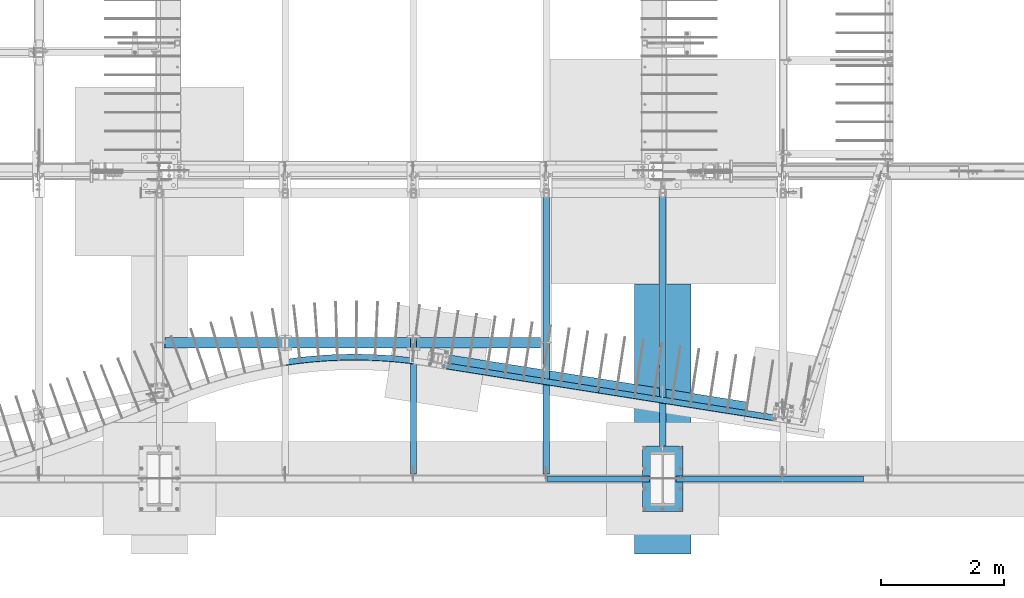
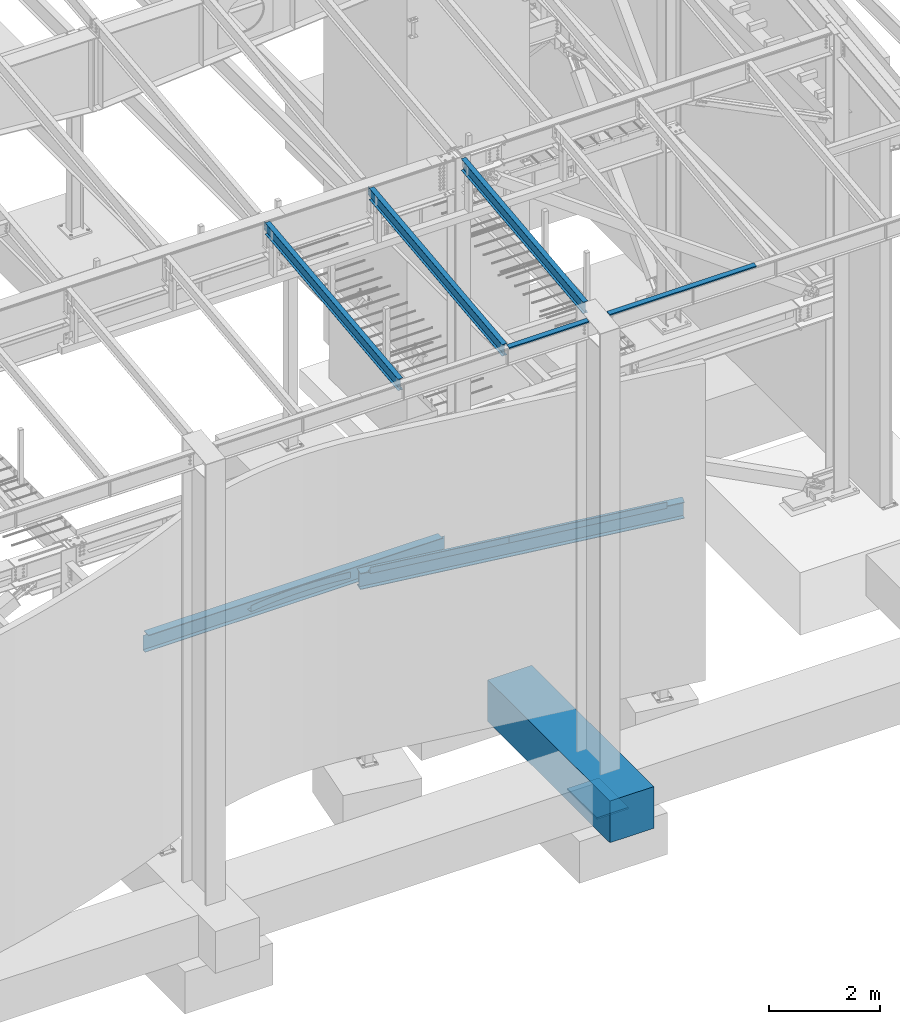
# One storey, part 712 of 1179: 12 beams, 10 elements without a shape of their own.
"""IFC2X3 building model written with IfcOpenShell, lengths in millimetres."""

from ifc_helpers import new_model, si_unit, frame, origin_with_axes, place, context, subcontext, project, spatial, faceted_brep, material, type_object, element, aggregate, save


model = new_model("IFC2X3")

# Units and contexts
model_context = context("Model", 3, precision=1e-05, world=origin_with_axes())
body_context = subcontext(model_context, "Body", "Model", "MODEL_VIEW")
ifc_project = project(units=[si_unit("LENGTHUNIT", "METRE", prefix="MILLI"), si_unit("AREAUNIT", "SQUARE_METRE"), si_unit("VOLUMEUNIT", "CUBIC_METRE"), si_unit("MASSUNIT", "GRAM", prefix="KILO"), si_unit("TIMEUNIT", "SECOND"), si_unit("PLANEANGLEUNIT", "RADIAN"), si_unit("SOLIDANGLEUNIT", "STERADIAN"), si_unit("THERMODYNAMICTEMPERATUREUNIT", "DEGREE_CELSIUS"), si_unit("LUMINOUSINTENSITYUNIT", "LUMEN")], contexts=[model_context])

# Site, building, storey
site_placement = place(None, origin_with_axes())
site = spatial("IfcSite", under=ifc_project, at=site_placement, CompositionType="ELEMENT")
building_placement = place(site_placement, origin_with_axes())
building = spatial("IfcBuilding", under=site, at=building_placement, Name="Undefined", CompositionType="ELEMENT")
storey_placement = place(building_placement, origin_with_axes())
storey = spatial("IfcBuildingStorey", under=building, at=storey_placement, Name="Undefined", CompositionType="ELEMENT", Elevation=0.0)

# Assembly, beam
assembly_1_placement = place(storey_placement, origin_with_axes())
assembly_1 = element("IfcElementAssembly", 1, at=assembly_1_placement, inside=storey, Name="BEAM", AssemblyPlace="NOTDEFINED", PredefinedType="RIGID_FRAME")
ifc_material_1 = material(Name="STEEL/A992")
beam_type_1 = type_object("IfcBeamType", Name="W10X12", PredefinedType="NOTDEFINED")
beam_1_placement = place(assembly_1_placement, frame((16459.2, 452.231593993459, 9171.78056384809), z_axis=(-3.89779463887408e-08, -0.112282221021699, 0.993676357192035), x_axis=(0.0, 0.993676357192036, 0.112282221021699)))
beam_1 = element("IfcBeam", 2, at=beam_1_placement, type_object=beam_type_1, material=ifc_material_1, Name="BEAM", ObjectType="W10X12", context=body_context, shape_type="Brep", body=[
    faceted_brep([(425.376742541311, -50.7999999999993, -125.412499999868), (425.376742541311, 50.7999999999993, -125.412499999868), (4829.96729994187, 50.7999999999993, -125.412499999367), (4829.96729994187, -50.7999999999993, -125.412499999367), (425.914889669142, -50.7999999999993, -120.64999999987), (425.914889669142, -2.38124999999854, -120.64999999987), (453.181010812576, -2.38124999999854, 120.649999999971), (453.181010812576, -50.7999999999993, 120.649999999971), (453.719157940407, -50.7999999999993, 125.412499999969), (453.719157940407, 50.7999999999993, 125.412499999969), (453.181010812576, 50.7999999999993, 120.649999999971), (453.181010812576, 2.38124999999854, 120.649999999971), (449.277251936401, 2.38124999999854, 86.1024744511342), (431.940877010644, 2.38124999999854, -67.3211550991127), (425.914889669142, 2.38124999999854, -120.64999999987), (425.914889669142, 50.7999999999993, -120.64999999987), (4830.5054470697, -50.7999999999993, -120.649999999372), (4830.5054470697, -2.38124999999854, -120.649999999372), (4857.77156821313, -2.38124999999854, 120.650000000471), (4857.77156821313, -50.7999999999993, 120.650000000471), (4858.30971534096, -50.7999999999993, 125.412500000468), (4858.30971534096, 50.7999999999993, 125.412500000468), (4857.77156821313, 50.7999999999993, 120.650000000471), (4857.77156821313, 2.38124999999854, 120.650000000471), (4853.01052424056, 2.38124999999854, 78.5156639672023), (4835.6741493148, 2.38124999999854, -74.9079655830446), (4830.5054470697, 2.38124999999854, -120.649999999372), (4830.5054470697, 50.7999999999993, -120.649999999372)], [[[0, 1, 2, 3]], [[0, 4, 5, 6, 7, 8, 9, 10, 11, 12, 13, 14, 15, 1]], [[5, 4, 16, 17]], [[6, 5, 17, 18]], [[7, 6, 18, 19]], [[8, 7, 19, 20]], [[9, 8, 20, 21]], [[10, 9, 21, 22]], [[11, 10, 22, 23]], [[14, 13, 12, 11, 23, 24, 25, 26]], [[15, 14, 26, 27]], [[1, 15, 27, 2]], [[26, 25, 24, 23, 22, 21, 20, 19, 18, 17, 16, 3, 2, 27]], [[4, 0, 3, 16]]]),
])
aggregate(assembly_1, [beam_1])

assembly_2_placement = place(storey_placement, origin_with_axes())
assembly_2 = element("IfcElementAssembly", 3, at=assembly_2_placement, inside=storey, Name="BEAM", AssemblyPlace="NOTDEFINED", PredefinedType="RIGID_FRAME")
beam_2_placement = place(assembly_2_placement, frame((14566.9, 452.231593993459, 9171.78056384809), z_axis=(-3.89779463887408e-08, -0.112282221021699, 0.993676357192035), x_axis=(0.0, 0.993676357192036, 0.112282221021699)))
beam_2 = element("IfcBeam", 4, at=beam_2_placement, type_object=beam_type_1, material=ifc_material_1, Name="BEAM", ObjectType="W10X12", context=body_context, shape_type="Brep", body=[
    faceted_brep([(4857.69134886906, 2.38125000000036, -120.649999999367), (4857.69134886908, 2.38119321150953, -125.412499999362), (4857.69133715173, 50.7999999999993, -125.412499999366), (4857.69133715173, 50.7999999999993, -120.649999999367), (4982.28709465017, 2.38125000000036, -120.649999999352), (4981.74894752234, 2.38122323349126, -125.412499999349), (48.8806597554974, -2.38124999999854, -120.649999999914), (48.8806597554974, -50.7999999999993, -120.649999999914), (4857.69136171279, -50.7999999999993, -120.649999999368), (4857.69134999544, -2.38125000000036, -120.649999999367), (76.1467808989316, 2.38124999999854, 120.649999999929), (76.1467808989316, 50.7999999999993, 120.649999999929), (4881.74500230402, 50.7999999999993, 120.650000000474), (4881.74500230402, 2.38125000000036, 120.650000000474), (48.3425126276663, -50.7999999999993, -125.412499999911), (76.1467808989316, -2.38124999999854, 120.649999999929), (76.1467808989316, -50.7999999999993, 120.649999999929), (76.6849280267622, -50.7999999999993, 125.412499999924), (76.6849280267622, 50.7999999999993, 125.412499999924), (48.8806597554974, 2.38124999999854, -120.649999999914), (48.8806597554974, 50.7999999999993, -120.649999999914), (48.3425126276663, 50.7999999999993, -125.412499999911), (4857.69136171279, -50.7999999999993, -125.412499999366), (4857.69134999547, -2.38130675233151, -125.412499999364), (4982.28709465017, -2.38125000000036, -120.649999999352), (4981.74894752234, -2.38127673034069, -125.412499999349), (4884.49824407442, -2.38125000000036, 75.1923220895023), (4880.7132366458, -2.38125000000036, 78.3905494782684), (4878.44025438672, -2.38125000000036, 82.793785937376), (4878.02533824148, -2.38125000000036, 87.7316786313622), (4881.74500230402, -2.38125000000036, 120.650000000474), (4982.37312427097, -2.38125000000036, -119.888654174249), (5002.79625141886, -2.38125000000036, 60.8521470148644), (4889.21904360274, -2.38125000000036, 73.6860048990093), (4881.74500230402, -50.7999999999993, 120.650000000474), (4882.28314943185, -50.7999999999993, 125.41250000047), (4882.28314943185, 50.7999999999993, 125.41250000047), (4878.02533824148, 2.38125000000036, 87.7316786313622), (4878.44025438672, 2.38125000000036, 82.793785937376), (4880.7132366458, 2.38125000000036, 78.3905494782684), (4884.49824407442, 2.38125000000036, 75.1923220895023), (4889.21904360274, 2.38125000000036, 73.6860048990093), (5002.79625141886, 2.38125000000036, 60.8521470148644), (4982.37311143735, 2.38125000000036, -119.888767749362)], [[[0, 1, 2, 3]], [[4, 5, 1, 0]], [[6, 7, 8, 9]], [[10, 11, 12, 13]], [[14, 7, 6, 15, 16, 17, 18, 11, 10, 19, 20, 21]], [[7, 14, 22, 8]], [[8, 22, 23, 9]], [[24, 9, 23, 25]], [[26, 27, 28, 29, 30, 15, 6, 9, 24, 31, 32, 33]], [[16, 15, 30, 34]], [[17, 16, 34, 35]], [[18, 17, 35, 36]], [[11, 18, 36, 12]], [[35, 34, 30, 29, 37, 13, 12, 36]], [[28, 38, 37, 29]], [[27, 39, 38, 28]], [[26, 40, 39, 27]], [[33, 41, 40, 26]], [[32, 42, 41, 33]], [[43, 4, 0, 19, 10, 13, 37, 38, 39, 40, 41, 42]], [[20, 19, 0, 3]], [[21, 20, 3, 2]], [[25, 23, 22, 14, 21, 2, 1, 5]], [[43, 42, 32, 31, 24, 25, 5, 4]]]),
])
aggregate(assembly_2, [beam_2])

assembly_3_placement = place(storey_placement, origin_with_axes())
assembly_3 = element("IfcElementAssembly", 5, at=assembly_3_placement, inside=storey, Name="BEAM", AssemblyPlace="NOTDEFINED", PredefinedType="RIGID_FRAME")
beam_3_placement = place(assembly_3_placement, frame((12407.9, 452.231593993459, 9171.78056384809), z_axis=(-3.89779463887408e-08, -0.112282221021699, 0.993676357192035), x_axis=(0.0, 0.993676357192036, 0.112282221021699)))
beam_3 = element("IfcBeam", 6, at=beam_3_placement, type_object=beam_type_1, material=ifc_material_1, Name="BEAM", ObjectType="W10X12", context=body_context, shape_type="Brep", body=[
    faceted_brep([(4857.69134886906, 2.38125000000036, -120.649999999367), (4857.69134886908, 2.38119321150953, -125.412499999362), (4857.69133715173, 50.7999999999993, -125.412499999366), (4857.69133715173, 50.7999999999993, -120.649999999367), (4982.28709465017, 2.38125000000036, -120.649999999352), (4981.74894752234, 2.38122323349126, -125.412499999349), (48.8806597554974, -2.38124999999854, -120.649999999914), (48.8806597554974, -50.7999999999993, -120.649999999914), (4857.69136171279, -50.7999999999993, -120.649999999368), (4857.69134999544, -2.38125000000036, -120.649999999367), (76.1467808989316, 2.38124999999854, 120.649999999929), (76.1467808989316, 50.7999999999993, 120.649999999929), (4881.74500230402, 50.7999999999993, 120.650000000474), (4881.74500230402, 2.38125000000036, 120.650000000474), (48.3425126276663, -50.7999999999993, -125.412499999911), (76.1467808989316, -2.38124999999854, 120.649999999929), (76.1467808989316, -50.7999999999993, 120.649999999929), (76.6849280267622, -50.7999999999993, 125.412499999924), (76.6849280267622, 50.7999999999993, 125.412499999924), (48.8806597554974, 2.38124999999854, -120.649999999914), (48.8806597554974, 50.7999999999993, -120.649999999914), (48.3425126276663, 50.7999999999993, -125.412499999911), (4857.69136171279, -50.7999999999993, -125.412499999366), (4857.69134999547, -2.38130675233151, -125.412499999364), (4982.28709465017, -2.38125000000036, -120.649999999352), (4981.74894752234, -2.38127673034069, -125.412499999349), (4884.49824407442, -2.38125000000036, 75.1923220895023), (4880.7132366458, -2.38125000000036, 78.3905494782684), (4878.44025438672, -2.38125000000036, 82.793785937376), (4878.02533824148, -2.38125000000036, 87.7316786313622), (4881.74500230402, -2.38125000000036, 120.650000000474), (4982.37312427097, -2.38125000000036, -119.888654174249), (5002.79625141886, -2.38125000000036, 60.8521470148644), (4889.21904360274, -2.38125000000036, 73.6860048990093), (4881.74500230402, -50.7999999999993, 120.650000000474), (4882.28314943185, -50.7999999999993, 125.41250000047), (4882.28314943185, 50.7999999999993, 125.41250000047), (4878.02533824148, 2.38125000000036, 87.7316786313622), (4878.44025438672, 2.38125000000036, 82.793785937376), (4880.7132366458, 2.38125000000036, 78.3905494782684), (4884.49824407442, 2.38125000000036, 75.1923220895023), (4889.21904360274, 2.38125000000036, 73.6860048990093), (5002.79625141886, 2.38125000000036, 60.8521470148644), (4982.37311143735, 2.38125000000036, -119.888767749362)], [[[0, 1, 2, 3]], [[4, 5, 1, 0]], [[6, 7, 8, 9]], [[10, 11, 12, 13]], [[14, 7, 6, 15, 16, 17, 18, 11, 10, 19, 20, 21]], [[7, 14, 22, 8]], [[8, 22, 23, 9]], [[24, 9, 23, 25]], [[26, 27, 28, 29, 30, 15, 6, 9, 24, 31, 32, 33]], [[16, 15, 30, 34]], [[17, 16, 34, 35]], [[18, 17, 35, 36]], [[11, 18, 36, 12]], [[35, 34, 30, 29, 37, 13, 12, 36]], [[28, 38, 37, 29]], [[27, 39, 38, 28]], [[26, 40, 39, 27]], [[33, 41, 40, 26]], [[32, 42, 41, 33]], [[43, 4, 0, 19, 10, 13, 37, 38, 39, 40, 41, 42]], [[20, 19, 0, 3]], [[21, 20, 3, 2]], [[25, 23, 22, 14, 21, 2, 1, 5]], [[43, 42, 32, 31, 24, 25, 5, 4]]]),
])
aggregate(assembly_3, [beam_3])

assembly_4_placement = place(storey_placement, origin_with_axes())
assembly_4 = element("IfcElementAssembly", 7, at=assembly_4_placement, inside=storey, Name="BEAM", AssemblyPlace="NOTDEFINED", PredefinedType="RIGID_FRAME")
ifc_material_2 = material(Name="STEEL/A36")
beam_type_2 = type_object("IfcBeamType", PredefinedType="NOTDEFINED")
beam_4_placement = place(assembly_4_placement, frame((15417.7999999992, 485.774999119925, 9265.24531304383), z_axis=(-1.0, 0.0, 0.0), x_axis=(0.0, 0.0, 1.0)))
beam_4 = element("IfcBeam", 8, at=beam_4_placement, type_object=beam_type_2, material=ifc_material_2, Name="BENT_PLATE", context=body_context, shape_type="Brep", body=[
    faceted_brep([(-2.18278728425503e-11, -3.17500000000001, -828.674999999999), (-2.18278728425503e-11, -3.17500000000001, 828.674999999999), (2.18278728425503e-11, 3.17500000000001, 828.674999999999), (2.18278728425503e-11, 3.17500000000001, -828.674999999999), (36.8806648309601, 3.17499999974928, 828.674999999999), (36.8806648309601, 3.17499999974928, -828.674999999999), (29.7727112136017, -3.17500000020243, -828.674999999999), (29.7727112136017, -3.17500000020243, 828.674999999999), (25.3999996241091, -98.4249984738682, 828.674999999999), (25.3999996241091, -98.4249984738682, -828.674999999999), (19.7271291791621, -92.0749984738682, -828.674999999999), (19.7271291791621, -92.0749984738682, 828.674999999999), (1.16087903734297e-08, -98.4249984738682, 828.674999999999), (1.16087903734297e-08, -98.4249984738682, -828.674999999999), (1.16087903734297e-08, -92.0749984738682, 828.674999999999), (1.16087903734297e-08, -92.0749984738682, -828.674999999999)], [[[0, 1, 2, 3]], [[3, 2, 4, 5]], [[1, 0, 6, 7]], [[5, 4, 8, 9]], [[7, 6, 10, 11]], [[9, 8, 12, 13]], [[8, 4, 2, 1, 7, 11, 14, 12]], [[11, 10, 15, 14]], [[10, 6, 0, 3, 5, 9, 13, 15]], [[14, 15, 13, 12]]]),
])
aggregate(assembly_4, [beam_4])

assembly_5_placement = place(storey_placement, origin_with_axes())
assembly_5 = element("IfcElementAssembly", 9, at=assembly_5_placement, inside=storey, Name="BEAM", AssemblyPlace="NOTDEFINED", PredefinedType="RIGID_FRAME")
beam_5_placement = place(assembly_5_placement, frame((18195.9249999997, 485.77499911942, 9265.25966886804), z_axis=(-1.0, 0.0, 0.0), x_axis=(0.0, 0.0, 1.0)))
beam_5 = element("IfcBeam", 10, at=beam_5_placement, type_object=beam_type_2, material=ifc_material_2, Name="BENT_PLATE", context=body_context, shape_type="Brep", body=[
    faceted_brep([(0.0, -3.17499999999927, -1524.0), (6.00266503170133e-10, -3.17499999922438, 1524.00000000052), (6.00266503170133e-10, 3.17500000077416, 1524.00000000052), (0.0, 3.17499999999927, -1524.0), (36.8806648358295, 3.17499999974928, 1524.0), (36.8806648358295, 3.17499999974928, -1524.0), (29.7727112184712, -3.17500000020243, -1524.0), (29.7727112184712, -3.17500000020243, 1524.0), (25.3999996289767, -98.4249984738682, 1524.0), (25.3999996289767, -98.4249984738682, -1524.0), (19.7271291840298, -92.0749984738682, -1524.0), (19.7271291840298, -92.0749984738682, 1524.0), (2.13476596400142e-08, -98.4249984738682, 1524.0), (2.13476596400142e-08, -98.4249984738682, -1524.0), (2.13476596400142e-08, -92.0749984738682, 1524.0), (2.13476596400142e-08, -92.0749984738682, -1524.0)], [[[0, 1, 2, 3]], [[3, 2, 4, 5]], [[1, 0, 6, 7]], [[5, 4, 8, 9]], [[7, 6, 10, 11]], [[9, 8, 12, 13]], [[8, 4, 2, 1, 7, 11, 14, 12]], [[11, 10, 15, 14]], [[10, 6, 0, 3, 5, 9, 13, 15]], [[14, 15, 13, 12]]]),
])
aggregate(assembly_5, [beam_5])

# Assembly, beams
assembly_6_placement = place(storey_placement, origin_with_axes())
assembly_6 = element("IfcElementAssembly", 11, at=assembly_6_placement, inside=storey, Name="BEAM", AssemblyPlace="NOTDEFINED", PredefinedType="RIGID_FRAME")
beam_type_3 = type_object("IfcBeamType", PredefinedType="NOTDEFINED")
beam_6_placement = place(assembly_6_placement, frame((18430.8294713993, 1402.72189346542, 3914.775), z_axis=(0.0, 0.0, 1.0), x_axis=(-0.987705568107644, 0.156325656017037, 0.0)))
beam_6 = element("IfcBeam", 12, at=beam_6_placement, type_object=beam_type_3, material=ifc_material_2, Name="BENT_PLATE", context=body_context, shape_type="Brep", body=[
    faceted_brep([(6.91215973347425e-11, 50.8000000000129, -66.6750000000002), (6.91215973347425e-11, 50.8000000000129, 66.6750000000002), (3047.99995452361, 50.7999999992289, 66.6750000000002), (3047.99995452361, 50.7999999992289, -66.6750000000002), (6.18456397205591e-11, 44.4500000000126, 66.6750000000002), (3047.9999545236, 44.4499999992267, 66.6750000000002), (6.18456397205591e-11, 44.4500000000126, -60.3249999999998), (3047.9999545236, 44.4499999992267, -60.3249999999998), (-1.81898940354586e-11, -50.8000000000038, -60.3249999999998), (3047.99995452347, -50.8000000007987, -60.3249999999998), (-1.81898940354586e-11, -50.8000000000038, -66.6750000000002), (3047.99995452347, -50.8000000007987, -66.6750000000002)], [[[0, 1, 2, 3]], [[1, 4, 5, 2]], [[4, 6, 7, 5]], [[6, 8, 9, 7]], [[8, 10, 11, 9]], [[10, 0, 3, 11]], [[5, 7, 9, 11, 3, 2]], [[10, 8, 6, 4, 1, 0]]]),
])
beam_7_placement = place(assembly_6_placement, frame((15420.3022815634, 1879.20259084773, 3914.775), z_axis=(0.0, 0.0, 1.0), x_axis=(-0.987707634095863, 0.156312602015171, 0.0)))
beam_7 = element("IfcBeam", 13, at=beam_7_placement, type_object=beam_type_3, material=ifc_material_2, Name="BENT_PLATE", context=body_context, shape_type="Brep", body=[
    faceted_brep([(6.91215973347425e-11, 50.8000000000129, -66.6750000000002), (6.91215973347425e-11, 50.8000000000129, 66.6750000000002), (2667.76328251084, 50.8000000004276, 66.6750000000002), (2667.76328251084, 50.8000000004276, -66.6750000000002), (6.18456397205591e-11, 44.4500000000126, 66.6750000000002), (2667.76328251084, 44.4500000004282, 66.6750000000002), (6.18456397205591e-11, 44.4500000000126, -60.3249999999998), (2667.76328251084, 44.4500000004282, -60.3249999999998), (-1.81898940354586e-11, -50.8000000000038, -60.3249999999998), (2667.76328251081, -50.7999999995754, -60.3249999999998), (-1.81898940354586e-11, -50.8000000000038, -66.6750000000002), (2667.76328251081, -50.7999999995754, -66.6750000000002)], [[[0, 1, 2, 3]], [[1, 4, 5, 2]], [[4, 6, 7, 5]], [[6, 8, 9, 7]], [[8, 10, 11, 9]], [[10, 0, 3, 11]], [[5, 7, 9, 11, 3, 2]], [[10, 8, 6, 4, 1, 0]]]),
])

# Assembly, beam
assembly_7_placement = place(storey_placement, origin_with_axes())
assembly_7 = element("IfcElementAssembly", 14, at=assembly_7_placement, inside=storey, Name="BENT_PLATE", AssemblyPlace="NOTDEFINED", PredefinedType="RIGID_FRAME")
beam_8_placement = place(assembly_7_placement, frame((12403.0616898379, 2353.25123770649, 3914.775), z_axis=(0.0, 0.0, 1.0), x_axis=(-0.998273872369731, 0.0587305350217522, 0.0)))
beam_8 = element("IfcBeam", 15, at=beam_8_placement, type_object=beam_type_3, material=ifc_material_2, Name="BENT_PLATE", context=body_context, shape_type="Brep", body=[
    faceted_brep([(-7.11686270076279, -50.5504329798782, -66.6750000000002), (-7.11686270076279, -50.5504329798782, -60.3249999999998), (-0.44480391288198, 44.4655979387585, -60.3249999999998), (-0.44480391288198, 44.4655979387585, 66.6750000000002), (6.91215973347425e-11, 50.8000000000129, 66.6750000000002), (6.91215973347425e-11, 50.8000000000129, -66.6750000000002), (460.718992330869, -68.7590154829581, -60.3249999999998), (694.835206571552, -66.9083352136249, -60.3249999999998), (928.779712278621, -57.7543722837686, -60.3249999999998), (1162.32473818047, -41.3060391052036, -60.3249999999998), (1395.24290194397, -17.5793499790702, -60.3249999999998), (1627.30743155674, 13.4025944958948, -60.3249999999998), (1858.29238611521, 51.6096299143801, -60.3249999999998), (2087.97287580345, 97.0045574329415, -60.3249999999998), (2068.04897890142, 190.147462864531, -60.3249999999998), (1841.28415053992, 145.328797765017, -60.3249999999998), (1613.23141673723, 107.606778621661, -60.3249999999998), (1384.11281246281, 77.0181320600514, -60.3249999999998), (1154.15141043079, 53.5926395657693, -60.3249999999998), (923.57110391367, 37.3531084887804, -60.3249999999998), (692.596388757014, 28.3153498379079, -60.3249999999998), (461.452144807532, 26.4881628870398, -60.3249999999998), (230.363416967279, 31.8733266080471, -60.3249999999998), (226.659008005754, -63.3046112465099, -60.3249999999998), (230.363416967279, 31.8733266080471, 66.6750000000002), (461.452144807532, 26.4881628870398, 66.6750000000002), (692.596388757014, 28.3153498379079, 66.6750000000002), (923.57110391367, 37.3531084887804, 66.6750000000002), (1154.15141043079, 53.5926395657693, 66.6750000000002), (1384.11281246281, 77.0181320600514, 66.6750000000002), (1613.23141673723, 107.606778621661, 66.6750000000002), (1841.28415053991, 145.328797765017, 66.6750000000002), (2068.04897890142, 190.147462864531, 66.6750000000002), (2066.72071910795, 196.356989893304, 66.6750000000002), (1840.15026816823, 151.576742288393, 66.6750000000002), (1612.29301574926, 113.887057563379, 66.6750000000002), (1383.3708064974, 83.324630862659, 66.6750000000002), (1153.60652191415, 59.9192181438352, 66.6750000000002), (923.223863356006, 43.6936072069516, 66.6750000000002), (692.447134236043, 34.6635955080101, 66.6750000000002), (461.501021639311, 32.8379747783729, 66.6750000000002), (230.610377564712, 38.2185224650175, 66.6750000000002), (230.610377564712, 38.2185224650175, -66.6750000000002), (461.501021639311, 32.8379747783729, -66.6750000000002), (692.447134236043, 34.6635955080101, -66.6750000000002), (923.223863356006, 43.6936072069516, -66.6750000000002), (1153.60652191415, 59.9192181438352, -66.6750000000002), (1383.3708064974, 83.324630862659, -66.6750000000002), (1612.29301574926, 113.887057563379, -66.6750000000002), (1840.15026816823, 151.576742288393, -66.6750000000002), (2066.72071910795, 196.356989893304, -66.6750000000002), (2087.97287580345, 97.0045574329415, -66.6750000000002), (1858.29238611521, 51.6096299143801, -66.6750000000002), (1627.30743155674, 13.4025944958948, -66.6750000000002), (1395.24290194397, -17.5793499790702, -66.6750000000002), (1162.32473818047, -41.3060391052036, -66.6750000000002), (928.779712278621, -57.7543722837686, -66.6750000000002), (694.835206571552, -66.9083352136249, -66.6750000000002), (460.718992330869, -68.7590154829581, -66.6750000000002), (226.659008005754, -63.3046112465099, -66.6750000000002)], [[[0, 1, 2, 3, 4, 5]], [[6, 7, 8, 9, 10, 11, 12, 13, 14, 15, 16, 17, 18, 19, 20, 21, 22, 2, 1, 23]], [[3, 2, 22, 24]], [[25, 26, 27, 28, 29, 30, 31, 32, 33, 34, 35, 36, 37, 38, 39, 40, 41, 4, 3, 24]], [[5, 4, 41, 42]], [[43, 44, 45, 46, 47, 48, 49, 50, 51, 52, 53, 54, 55, 56, 57, 58, 59, 0, 5, 42]], [[1, 0, 59, 23]], [[59, 58, 6, 23]], [[41, 40, 43, 42]], [[22, 21, 25, 24]], [[58, 57, 7, 6]], [[40, 39, 44, 43]], [[21, 20, 26, 25]], [[57, 56, 8, 7]], [[39, 38, 45, 44]], [[20, 19, 27, 26]], [[56, 55, 9, 8]], [[38, 37, 46, 45]], [[19, 18, 28, 27]], [[55, 54, 10, 9]], [[37, 36, 47, 46]], [[18, 17, 29, 28]], [[54, 53, 11, 10]], [[36, 35, 48, 47]], [[17, 16, 30, 29]], [[53, 52, 12, 11]], [[35, 34, 49, 48]], [[16, 15, 31, 30]], [[32, 14, 13, 51, 50, 33]], [[52, 51, 13, 12]], [[34, 33, 50, 49]], [[15, 14, 32, 31]]]),
])
aggregate(assembly_7, [beam_8])

assembly_8_placement = place(storey_placement, origin_with_axes())
assembly_8 = element("IfcElementAssembly", 16, at=assembly_8_placement, inside=storey, Name="BEAM", AssemblyPlace="NOTDEFINED", PredefinedType="RIGID_FRAME")
beam_type_4 = type_object("IfcBeamType", Name="W14X30", PredefinedType="NOTDEFINED")
beam_9_placement = place(assembly_8_placement, frame((8280.4, 2647.95, 3671.8875), z_axis=(0.0, 0.0, 1.0), x_axis=(1.0, 0.0, 0.0)))
beam_9 = element("IfcBeam", 17, at=beam_9_placement, type_object=beam_type_4, material=ifc_material_1, Name="BEAM", ObjectType="W14X30", context=body_context, shape_type="Brep", body=[
    faceted_brep([(6188.075, -3.17500000000018, -166.6875), (6188.075, -85.7249999999999, -166.6875), (6188.075, -85.7249999999999, -176.2125), (6188.075, 85.7249999999999, -176.2125), (6188.075, 85.7249999999999, -166.6875), (6188.075, 3.17500673636596, -166.6875), (6188.075, 3.17518641205515, -157.162499809266), (6188.075, -3.17500000000018, -157.162499809266), (6189.04172992259, 3.17518275515386, -152.30242029122), (6189.04172992259, -3.17500000000018, -152.30242029122), (6191.79474382307, 3.17517965477964, -148.182243823067), (6191.79474382307, -3.17500000000018, -148.182243823067), (6195.91492029122, 3.1751775829357, -145.429229922589), (6195.91492029122, -3.17500000000018, -145.429229922589), (6200.77499980927, 3.17517685504254, -144.462500000001), (6200.77499980927, -3.17500000000018, -144.462500000001), (6270.625, -3.17500000000018, -144.462500000001), (6270.625, 3.17500000000018, -144.462500000001), (88.9000000000015, 3.17500000000291, 166.6875), (88.8999999989719, 85.7249999999999, 166.6875), (6188.075, 85.7249999999999, 166.6875), (6188.075, 3.17500000000018, 166.6875), (144.462499998968, 85.7249999999999, -166.6875), (144.462499998968, 85.7249999999999, -176.2125), (144.462499998968, 3.17549991607666, -176.2125), (144.462499998968, 3.17549991607666, -166.6875), (17.4624999989683, 3.17549991607666, -176.2125), (17.4624999989683, 3.17500000000018, -166.6875), (17.4624999989683, -85.7249999999999, -176.2125), (17.4624999989683, -85.7249999999999, -166.6875), (17.4624999989683, -3.17500000000018, -166.6875), (17.4624999989683, -3.17500000000018, 144.4625), (17.4624999989683, 3.17500000000018, 144.4625), (76.2000001897068, -3.17500000000018, 144.4625), (76.2000001897068, 3.17497410477199, 144.4625), (81.0600797077532, -3.17500000000018, 145.429229922588), (81.0600797077532, 3.174973379937, 145.429229922588), (85.1802561759068, -3.17500000000018, 148.182243823066), (85.1802561759068, 3.17497131578102, 148.182243823066), (87.9332700763844, -3.17500000000018, 152.30242029122), (87.9332700763844, 3.17496822655357, 152.30242029122), (88.8999999989719, -3.17500000000018, 157.162499809265), (88.8999999989719, 3.17496458256119, 157.162499809265), (88.8999999989719, -85.7249999999999, 176.2125), (88.8999999989719, 85.7249999999999, 176.2125), (88.9000000000015, -3.17500000000291, 166.6875), (88.8999999989719, -85.7249999999999, 166.6875), (6188.075, -3.17500000000018, 166.6875), (6188.075, -85.7249999999999, 166.6875), (6188.075, -85.7249999999999, 176.2125), (6188.075, 85.7249999999999, 176.2125), (6188.075, -3.17500000000018, 157.162499809265), (6188.075, 3.17495205153546, 157.162499809265), (6189.04172992259, -3.17500000000018, 152.302420291219), (6189.04172992259, 3.17495570110577, 152.302420291219), (6191.79474382307, -3.17500000000018, 148.182243823066), (6191.79474382307, 3.1749587955801, 148.182243823066), (6195.91492029122, -3.17500000000018, 145.429229922588), (6195.91492029122, 3.17496086385245, 145.429229922588), (6200.77499980927, -3.17500000000018, 144.4625), (6200.77499980927, 3.17496159104758, 144.4625), (6270.625, -3.17500000000018, 144.4625), (6270.625, 3.17500000000018, 144.4625)], [[[0, 1, 2, 3, 4, 5, 6, 7]], [[7, 6, 8, 9]], [[9, 8, 10, 11]], [[11, 10, 12, 13]], [[13, 12, 14, 15]], [[16, 15, 14, 17]], [[18, 19, 20, 21]], [[22, 23, 24, 25]], [[25, 24, 26, 27]], [[27, 26, 28, 29, 30, 31, 32]], [[33, 34, 32, 31]], [[35, 36, 34, 33]], [[37, 38, 36, 35]], [[39, 40, 38, 37]], [[41, 42, 40, 39]], [[43, 44, 19, 18, 42, 41, 45, 46]], [[46, 45, 47, 48]], [[43, 46, 48, 49]], [[44, 43, 49, 50]], [[19, 44, 50, 20]], [[49, 48, 47, 51, 52, 21, 20, 50]], [[53, 54, 52, 51]], [[55, 56, 54, 53]], [[57, 58, 56, 55]], [[59, 60, 58, 57]], [[61, 62, 60, 59]], [[62, 61, 16, 17]], [[12, 10, 8, 6, 5, 25, 27, 32, 34, 36, 38, 40, 42, 18, 21, 52, 54, 56, 58, 60, 62, 17, 14]], [[22, 25, 5, 4]], [[23, 22, 4, 3]], [[28, 26, 24, 23, 3, 2]], [[29, 28, 2, 1]], [[30, 29, 1, 0]], [[61, 59, 57, 55, 53, 51, 47, 45, 41, 39, 37, 35, 33, 31, 30, 0, 7, 9, 11, 13, 15, 16]]]),
])
aggregate(assembly_8, [beam_9])

# Beam
beam_type_5 = type_object("IfcBeamType", Name="W14X38", PredefinedType="NOTDEFINED")
beam_10_placement = place(assembly_6_placement, frame((12644.5759112125, 2421.41210607514, 3668.7125), z_axis=(0.0, 0.0, 1.0), x_axis=(0.987705845081851, -0.156323906012954, 0.0)))
beam_10 = element("IfcBeam", 18, at=beam_10_placement, type_object=beam_type_5, material=ifc_material_1, Name="BEAM", ObjectType="W14X38", context=body_context, shape_type="Brep", body=[
    faceted_brep([(-5.0931703299284e-11, 85.7250000000067, -179.3875), (-5.0931703299284e-11, 85.7250000000067, -166.6875), (6260.12697534827, 85.725000000768, -166.6875), (6260.12697534827, 85.725000000768, -179.3875), (-1.81898940354586e-12, 3.96875000000091, -166.6875), (6247.17881725908, 3.96875000075943, -166.6875), (-1.81898940354586e-12, 3.96875000000091, 166.6875), (6247.17881725908, 3.96875000075943, 166.6875), (-5.0931703299284e-11, 85.7250000000067, 166.6875), (6260.12697534827, 85.725000000768, 166.6875), (-5.0931703299284e-11, 85.7250000000067, 179.3875), (6260.12697534827, 85.725000000768, 179.3875), (5.0931703299284e-11, -85.7250000000058, 179.3875), (6232.97355644279, -85.7249999992491, 179.3875), (5.0931703299284e-11, -85.7250000000058, 166.6875), (6232.97355644279, -85.7249999992491, 166.6875), (3.63797880709171e-12, -3.96875, 166.6875), (6245.92171453197, -3.96874999924148, 166.6875), (3.63797880709171e-12, -3.96875, -166.6875), (6245.92171453197, -3.96874999924148, -166.6875), (5.0931703299284e-11, -85.7250000000058, -166.6875), (6232.97355644279, -85.7249999992491, -166.6875), (5.0931703299284e-11, -85.7250000000058, -179.3875), (6232.97355644279, -85.7249999992491, -179.3875)], [[[0, 1, 2, 3]], [[1, 4, 5, 2]], [[4, 6, 7, 5]], [[6, 8, 9, 7]], [[8, 10, 11, 9]], [[10, 12, 13, 11]], [[12, 14, 15, 13]], [[14, 16, 17, 15]], [[16, 18, 19, 17]], [[18, 20, 21, 19]], [[20, 22, 23, 21]], [[22, 0, 3, 23]], [[5, 7, 9, 11, 13, 15, 17, 19, 21, 23, 3, 2]], [[22, 20, 18, 16, 14, 12, 10, 8, 6, 4, 1, 0]]]),
])

aggregate(assembly_6, [beam_6, beam_7, beam_10])

# Assembly, beam
assembly_9_placement = place(storey_placement, origin_with_axes())
assembly_9 = element("IfcElementAssembly", 19, at=assembly_9_placement, inside=storey, Name="GRADE_BEAM", AssemblyPlace="NOTDEFINED", PredefinedType="REINFORCEMENT_UNIT")
ifc_material_3 = material(Name="CONCRETE/5000")
beam_type_6 = type_object("IfcBeamType", PredefinedType="NOTDEFINED")
beam_11_placement = place(assembly_9_placement, frame((16459.2, -781.05, -889.0), z_axis=(0.0, 0.0, 1.0), x_axis=(0.0, 1.0, 0.0)))
beam_11 = element("IfcBeam", 20, at=beam_11_placement, type_object=beam_type_6, material=ifc_material_3, Name="GRADE_BEAM", context=body_context, shape_type="Brep", body=[
    faceted_brep([(4.84305928694084e-11, 457.2, -457.2), (4.84305928694084e-11, 457.2, 457.2), (4387.85000000001, 457.200000000001, 457.2), (4387.85000000001, 457.200000000001, -457.2), (-4.82032191939652e-11, -457.2, 457.2), (4387.85000000001, -457.200000000001, 457.2), (-4.82032191939652e-11, -457.2, -457.2), (4387.85000000001, -457.200000000001, -457.2)], [[[0, 1, 2, 3]], [[1, 4, 5, 2]], [[4, 6, 7, 5]], [[6, 0, 3, 7]], [[5, 7, 3, 2]], [[6, 4, 1, 0]]]),
])
aggregate(assembly_9, [beam_11])

assembly_10_placement = place(storey_placement, origin_with_axes())
assembly_10 = element("IfcElementAssembly", 21, at=assembly_10_placement, inside=storey, Name="COLUMN", AssemblyPlace="NOTDEFINED", PredefinedType="RIGID_FRAME")
ifc_material_4 = material(Name="STEEL/A572-GR.50")
beam_type_7 = type_object("IfcBeamType", PredefinedType="NOTDEFINED")
beam_12_placement = place(assembly_10_placement, frame((16459.2, -95.25, -1276.35), z_axis=(-1.0, 0.0, 0.0), x_axis=(0.0, 1.0, 0.0)))
beam_12 = element("IfcBeam", 22, at=beam_12_placement, type_object=beam_type_7, material=ifc_material_4, context=body_context, shape_type="Brep", body=[
    faceted_brep([(0.0, 19.05, -330.200000000001), (0.0, 19.05, 330.2), (1066.80000000029, 19.05, 330.2), (1066.80000000029, 19.05, -330.200000000001), (0.0, -19.05, 330.2), (1066.80000000029, -19.05, 330.2), (0.0, -19.05, -330.200000000001), (1066.80000000029, -19.05, -330.200000000001)], [[[0, 1, 2, 3]], [[1, 4, 5, 2]], [[4, 6, 7, 5]], [[6, 0, 3, 7]], [[5, 7, 3, 2]], [[6, 4, 1, 0]]]),
])
aggregate(assembly_10, [beam_12])

save(model, "model.ifc")
